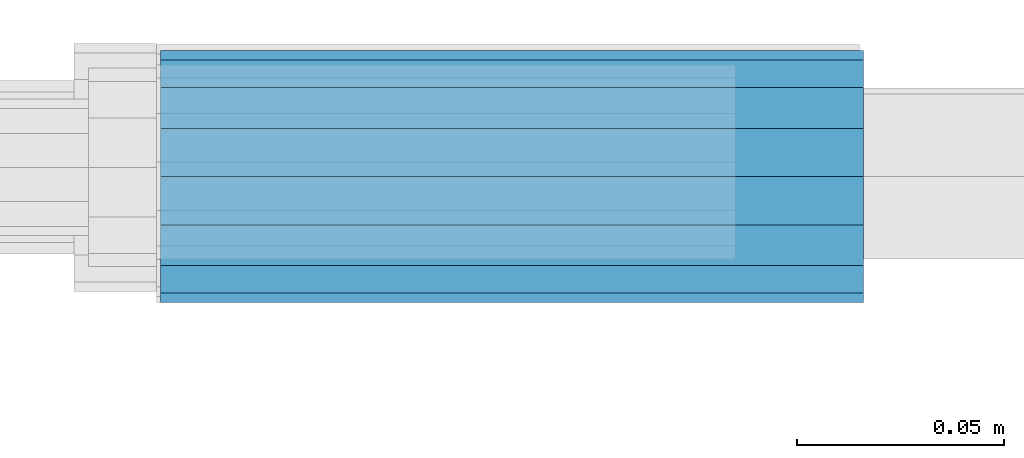
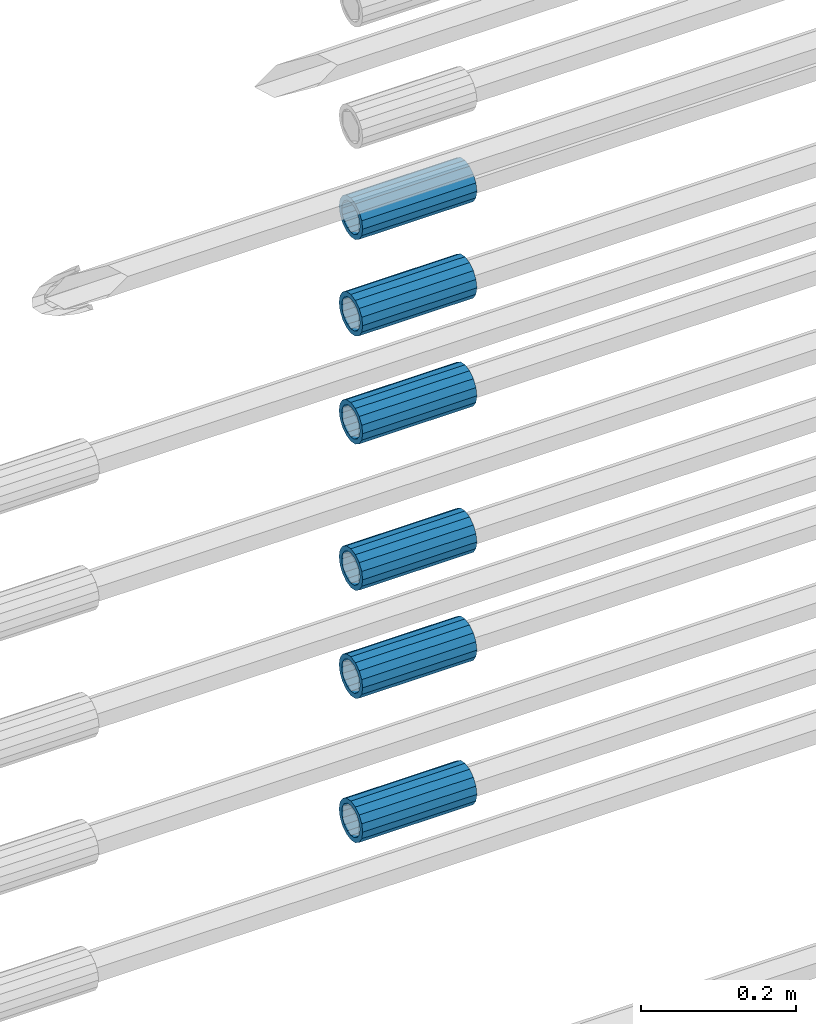
# One storey, part 12 of 119: 6 beams.
"""IFC2X3 building model written with IfcOpenShell, lengths in millimetres."""

from ifc_helpers import new_model, si_unit, frame, origin_with_axes, place, context, subcontext, project, spatial, faceted_brep, material, type_object, element, save


model = new_model("IFC2X3")

# Units and contexts
model_context = context("Model", 3, precision=1e-05, world=origin_with_axes())
body_context = subcontext(model_context, "Body", "Model", "MODEL_VIEW")
ifc_project = project(units=[si_unit("LENGTHUNIT", "METRE", prefix="MILLI"), si_unit("AREAUNIT", "SQUARE_METRE"), si_unit("VOLUMEUNIT", "CUBIC_METRE"), si_unit("MASSUNIT", "GRAM", prefix="KILO"), si_unit("TIMEUNIT", "SECOND"), si_unit("PLANEANGLEUNIT", "RADIAN"), si_unit("SOLIDANGLEUNIT", "STERADIAN"), si_unit("THERMODYNAMICTEMPERATUREUNIT", "DEGREE_CELSIUS"), si_unit("LUMINOUSINTENSITYUNIT", "LUMEN")], contexts=[model_context])

# Site, building, storey
site_placement = place(None, origin_with_axes())
site = spatial("IfcSite", under=ifc_project, at=site_placement, CompositionType="ELEMENT")
building_placement = place(site_placement, origin_with_axes())
building = spatial("IfcBuilding", under=site, at=building_placement, Name="Undefined", CompositionType="ELEMENT")
storey_placement = place(building_placement, origin_with_axes())
storey = spatial("IfcBuildingStorey", under=building, at=storey_placement, Name="Undefined", CompositionType="ELEMENT", Elevation=0.0)

# Beams
ifc_material = material(Name="STEEL/S275")
beam_type = type_object("IfcBeamType", PredefinedType="NOTDEFINED")
beam_1_placement = place(storey_placement, frame((2032020.00007889, 6206399.98994599, 19957.6893084732), z_axis=(0.0, 0.0, 1.0), x_axis=(-0.99999999999998, 1.98000110685822e-07, 0.0)))
element("IfcBeam", 1, at=beam_1_placement, inside=storey, type_object=beam_type, material=ifc_material, Name="AG40N", context=body_context, shape_type="Brep", body=[
    faceted_brep([(1.62981450557709e-09, -23.4999999990687, 0.0), (7.45058059692383e-09, -21.7111690142192, 8.99306066057534), (170.000002125278, -21.711168999318, 8.99306066022245), (170.000002127141, -23.4999999844003, -3.66071617463604e-10), (4.65661287307739e-09, -16.6170093587134, 16.6170093578889), (170.000002122484, -16.6170093440451, 16.6170093575288), (1.86264514923096e-09, -8.99306066217832, 21.7111690140277), (170.000002118759, -8.99306064750999, 21.7111690136603), (2.3283064365387e-10, 9.31322574615479e-10, 23.5), (170.000002114102, 1.28056854009628e-08, 23.4999999996485), (-6.51925802230835e-09, 8.99306065868586, 21.7111690140241), (170.00000211224, 8.99306067335419, 21.7111690136639), (-7.45058059692383e-09, 16.6170093561523, 16.6170093578853), (170.000002109446, 16.6170093708206, 16.6170093575324), (-9.31322574615479e-09, 21.711169013055, 8.99306066057534), (170.000002108514, 21.7111690277234, 8.99306066022245), (-1.16415321826935e-09, 23.5000000009313, 0.0), (170.000002108514, 23.5000000144355, -3.66071617463604e-10), (-8.38190317153931e-09, 21.7111690151505, -8.99306066059444), (170.000002110377, 21.7111690300517, -8.9930606609546), (-5.58793544769287e-09, 16.6170093598776, -16.6170093579008), (170.000002113171, 16.6170093745459, -16.6170093582609), (-9.31322574615479e-10, 8.99306066334248, -21.7111690140396), (170.000002115965, 8.99306067801081, -21.7111690143961), (2.3283064365387e-10, 9.31322574615479e-10, -23.5), (170.00000211969, 1.7927959561348e-08, -23.5000000003843), (5.58793544769287e-09, -8.99306065752171, -21.7111690140396), (170.000002123415, -8.99306064285338, -21.7111690143961), (8.38190317153931e-09, -16.6170093549881, -16.6170093579008), (170.000002125278, -16.6170093403198, -16.6170093582646), (9.31322574615479e-09, -21.7111690121237, -8.99306066059444), (170.000002127141, -21.7111689972226, -8.9930606609546), (1.11758708953857e-08, -30.4999999990687, -9.54969436861575e-12), (1.30385160446167e-08, -28.1783257392235, -11.6718446871514), (170.000002129003, -28.1783257243223, -11.6718446875116), (170.000002129935, -30.4999999841675, -3.66071617463604e-10), (1.02445483207703e-08, -21.5667568228673, -21.5667568262129), (170.000002128072, -21.566756808199, -21.5667568265694), (7.45058059692383e-09, -11.6718446831219, -28.1783257416196), (170.000002125278, -11.6718446684536, -28.1783257419834), (3.72529029846191e-09, 3.95812094211578e-09, -30.5000000000277), (170.00000211969, 1.83936208486557e-08, -30.5000000003879), (-9.31322574615479e-10, 11.6718446905725, -28.1783257416232), (170.000002115965, 11.6718447052408, -28.1783257419797), (-6.51925802230835e-09, 21.5667568286881, -21.5667568262093), (170.000002110377, 21.5667568433564, -21.5667568265694), (-9.31322574615479e-09, 28.178325742716, -11.6718446871478), (170.000002108514, 28.1783257573843, -11.6718446875079), (-1.21071934700012e-08, 30.5, -5.91171556152403e-12), (170.000002106652, 30.5000000144355, -3.62433638656512e-10), (-1.21071934700012e-08, 28.1783257401548, 11.6718446871359), (170.00000210572, 28.1783257548232, 11.6718446867794), (-1.02445483207703e-08, 21.5667568240315, 21.5667568261974), (170.000002107583, 21.566756838467, 21.5667568258409), (-7.45058059692383e-09, 11.671844684286, 28.1783257416041), (170.000002110377, 11.6718446989544, 28.178325741244), (-2.79396772384644e-09, -2.56113708019257e-09, 30.5000000000159), (170.000002114102, 1.18743628263474e-08, 30.4999999996558), (1.86264514923096e-09, -11.6718446896411, 28.1783257416114), (170.000002118759, -11.67184467474, 28.178325741244), (7.45058059692383e-09, -21.5667568275239, 21.5667568261974), (170.000002123415, -21.5667568126228, 21.5667568258373), (1.02445483207703e-08, -28.1783257415518, 11.6718446871359), (170.000002127141, -28.1783257271163, 11.6718446867794)], [[[0, 1, 2, 3]], [[1, 4, 5, 2]], [[4, 6, 7, 5]], [[6, 8, 9, 7]], [[8, 10, 11, 9]], [[10, 12, 13, 11]], [[12, 14, 15, 13]], [[14, 16, 17, 15]], [[16, 18, 19, 17]], [[18, 20, 21, 19]], [[20, 22, 23, 21]], [[22, 24, 25, 23]], [[24, 26, 27, 25]], [[26, 28, 29, 27]], [[28, 30, 31, 29]], [[30, 0, 3, 31]], [[32, 33, 34, 35]], [[33, 36, 37, 34]], [[36, 38, 39, 37]], [[38, 40, 41, 39]], [[40, 42, 43, 41]], [[42, 44, 45, 43]], [[44, 46, 47, 45]], [[46, 48, 49, 47]], [[48, 50, 51, 49]], [[50, 52, 53, 51]], [[52, 54, 55, 53]], [[54, 56, 57, 55]], [[56, 58, 59, 57]], [[58, 60, 61, 59]], [[60, 62, 63, 61]], [[62, 32, 35, 63]], [[37, 39, 41, 43, 45, 47, 49, 51, 53, 55, 57, 59, 61, 63, 35, 34], [5, 7, 9, 11, 13, 15, 17, 19, 21, 23, 25, 27, 29, 31, 3, 2]], [[62, 60, 58, 56, 54, 52, 50, 48, 46, 44, 42, 40, 38, 36, 33, 32], [30, 28, 26, 24, 22, 20, 18, 16, 14, 12, 10, 8, 6, 4, 1, 0]]]),
])
beam_2_placement = place(storey_placement, frame((2032020.00007889, 6206399.98994599, 20184.6893084732), z_axis=(0.0, 0.0, 1.0), x_axis=(-0.99999999999998, 1.98000110685822e-07, 0.0)))
element("IfcBeam", 2, at=beam_2_placement, inside=storey, type_object=beam_type, material=ifc_material, Name="AG40N", context=body_context, shape_type="Brep", body=[
    faceted_brep([(1.62981450557709e-09, -23.4999999990687, 0.0), (7.45058059692383e-09, -21.7111690142192, 8.99306066057534), (170.000002125278, -21.711168999318, 8.99306066022245), (170.000002127141, -23.4999999844003, -3.66071617463604e-10), (4.65661287307739e-09, -16.6170093587134, 16.6170093578889), (170.000002122484, -16.6170093440451, 16.6170093575288), (1.86264514923096e-09, -8.99306066217832, 21.7111690140277), (170.000002118759, -8.99306064750999, 21.7111690136603), (2.3283064365387e-10, 9.31322574615479e-10, 23.5), (170.000002114102, 1.28056854009628e-08, 23.4999999996485), (-6.51925802230835e-09, 8.99306065868586, 21.7111690140241), (170.00000211224, 8.99306067335419, 21.7111690136639), (-7.45058059692383e-09, 16.6170093561523, 16.6170093578853), (170.000002109446, 16.6170093708206, 16.6170093575324), (-9.31322574615479e-09, 21.711169013055, 8.99306066057534), (170.000002108514, 21.7111690277234, 8.99306066022245), (-1.16415321826935e-09, 23.5000000009313, 0.0), (170.000002108514, 23.5000000144355, -3.66071617463604e-10), (-8.38190317153931e-09, 21.7111690151505, -8.99306066059444), (170.000002110377, 21.7111690300517, -8.9930606609546), (-5.58793544769287e-09, 16.6170093598776, -16.6170093579008), (170.000002113171, 16.6170093745459, -16.6170093582609), (-9.31322574615479e-10, 8.99306066334248, -21.7111690140396), (170.000002115965, 8.99306067801081, -21.7111690143961), (2.3283064365387e-10, 9.31322574615479e-10, -23.5), (170.00000211969, 1.7927959561348e-08, -23.5000000003843), (5.58793544769287e-09, -8.99306065752171, -21.7111690140396), (170.000002123415, -8.99306064285338, -21.7111690143961), (8.38190317153931e-09, -16.6170093549881, -16.6170093579008), (170.000002125278, -16.6170093403198, -16.6170093582646), (9.31322574615479e-09, -21.7111690121237, -8.99306066059444), (170.000002127141, -21.7111689972226, -8.9930606609546), (1.11758708953857e-08, -30.4999999990687, -9.54969436861575e-12), (1.30385160446167e-08, -28.1783257392235, -11.6718446871514), (170.000002129003, -28.1783257243223, -11.6718446875116), (170.000002129935, -30.4999999841675, -3.66071617463604e-10), (1.02445483207703e-08, -21.5667568228673, -21.5667568262129), (170.000002128072, -21.566756808199, -21.5667568265694), (7.45058059692383e-09, -11.6718446831219, -28.1783257416196), (170.000002125278, -11.6718446684536, -28.1783257419834), (3.72529029846191e-09, 3.95812094211578e-09, -30.5000000000277), (170.00000211969, 1.83936208486557e-08, -30.5000000003879), (-9.31322574615479e-10, 11.6718446905725, -28.1783257416232), (170.000002115965, 11.6718447052408, -28.1783257419797), (-6.51925802230835e-09, 21.5667568286881, -21.5667568262093), (170.000002110377, 21.5667568433564, -21.5667568265694), (-9.31322574615479e-09, 28.178325742716, -11.6718446871478), (170.000002108514, 28.1783257573843, -11.6718446875079), (-1.21071934700012e-08, 30.5, -5.91171556152403e-12), (170.000002106652, 30.5000000144355, -3.62433638656512e-10), (-1.21071934700012e-08, 28.1783257401548, 11.6718446871359), (170.00000210572, 28.1783257548232, 11.6718446867794), (-1.02445483207703e-08, 21.5667568240315, 21.5667568261974), (170.000002107583, 21.566756838467, 21.5667568258409), (-7.45058059692383e-09, 11.671844684286, 28.1783257416041), (170.000002110377, 11.6718446989544, 28.178325741244), (-2.79396772384644e-09, -2.56113708019257e-09, 30.5000000000159), (170.000002114102, 1.18743628263474e-08, 30.4999999996558), (1.86264514923096e-09, -11.6718446896411, 28.1783257416114), (170.000002118759, -11.67184467474, 28.178325741244), (7.45058059692383e-09, -21.5667568275239, 21.5667568261974), (170.000002123415, -21.5667568126228, 21.5667568258373), (1.02445483207703e-08, -28.1783257415518, 11.6718446871359), (170.000002127141, -28.1783257271163, 11.6718446867794)], [[[0, 1, 2, 3]], [[1, 4, 5, 2]], [[4, 6, 7, 5]], [[6, 8, 9, 7]], [[8, 10, 11, 9]], [[10, 12, 13, 11]], [[12, 14, 15, 13]], [[14, 16, 17, 15]], [[16, 18, 19, 17]], [[18, 20, 21, 19]], [[20, 22, 23, 21]], [[22, 24, 25, 23]], [[24, 26, 27, 25]], [[26, 28, 29, 27]], [[28, 30, 31, 29]], [[30, 0, 3, 31]], [[32, 33, 34, 35]], [[33, 36, 37, 34]], [[36, 38, 39, 37]], [[38, 40, 41, 39]], [[40, 42, 43, 41]], [[42, 44, 45, 43]], [[44, 46, 47, 45]], [[46, 48, 49, 47]], [[48, 50, 51, 49]], [[50, 52, 53, 51]], [[52, 54, 55, 53]], [[54, 56, 57, 55]], [[56, 58, 59, 57]], [[58, 60, 61, 59]], [[60, 62, 63, 61]], [[62, 32, 35, 63]], [[37, 39, 41, 43, 45, 47, 49, 51, 53, 55, 57, 59, 61, 63, 35, 34], [5, 7, 9, 11, 13, 15, 17, 19, 21, 23, 25, 27, 29, 31, 3, 2]], [[62, 60, 58, 56, 54, 52, 50, 48, 46, 44, 42, 40, 38, 36, 33, 32], [30, 28, 26, 24, 22, 20, 18, 16, 14, 12, 10, 8, 6, 4, 1, 0]]]),
])
beam_3_placement = place(storey_placement, frame((2032020.00007889, 6206399.98994599, 20354.6893084732), z_axis=(0.0, 0.0, 1.0), x_axis=(-0.99999999999998, 1.98000110685822e-07, 0.0)))
element("IfcBeam", 3, at=beam_3_placement, inside=storey, type_object=beam_type, material=ifc_material, Name="AG40N", context=body_context, shape_type="Brep", body=[
    faceted_brep([(1.62981450557709e-09, -23.4999999990687, 0.0), (7.45058059692383e-09, -21.7111690142192, 8.99306066057534), (170.000002125278, -21.711168999318, 8.99306066022245), (170.000002127141, -23.4999999844003, -3.66071617463604e-10), (4.65661287307739e-09, -16.6170093587134, 16.6170093578889), (170.000002122484, -16.6170093440451, 16.6170093575288), (1.86264514923096e-09, -8.99306066217832, 21.7111690140277), (170.000002118759, -8.99306064750999, 21.7111690136603), (2.3283064365387e-10, 9.31322574615479e-10, 23.5), (170.000002114102, 1.28056854009628e-08, 23.4999999996485), (-6.51925802230835e-09, 8.99306065868586, 21.7111690140241), (170.00000211224, 8.99306067335419, 21.7111690136639), (-7.45058059692383e-09, 16.6170093561523, 16.6170093578853), (170.000002109446, 16.6170093708206, 16.6170093575324), (-9.31322574615479e-09, 21.711169013055, 8.99306066057534), (170.000002108514, 21.7111690277234, 8.99306066022245), (-1.16415321826935e-09, 23.5000000009313, 0.0), (170.000002108514, 23.5000000144355, -3.66071617463604e-10), (-8.38190317153931e-09, 21.7111690151505, -8.99306066059444), (170.000002110377, 21.7111690300517, -8.9930606609546), (-5.58793544769287e-09, 16.6170093598776, -16.6170093579008), (170.000002113171, 16.6170093745459, -16.6170093582609), (-9.31322574615479e-10, 8.99306066334248, -21.7111690140396), (170.000002115965, 8.99306067801081, -21.7111690143961), (2.3283064365387e-10, 9.31322574615479e-10, -23.5), (170.00000211969, 1.7927959561348e-08, -23.5000000003843), (5.58793544769287e-09, -8.99306065752171, -21.7111690140396), (170.000002123415, -8.99306064285338, -21.7111690143961), (8.38190317153931e-09, -16.6170093549881, -16.6170093579008), (170.000002125278, -16.6170093403198, -16.6170093582646), (9.31322574615479e-09, -21.7111690121237, -8.99306066059444), (170.000002127141, -21.7111689972226, -8.9930606609546), (1.11758708953857e-08, -30.4999999990687, -9.54969436861575e-12), (1.30385160446167e-08, -28.1783257392235, -11.6718446871514), (170.000002129003, -28.1783257243223, -11.6718446875116), (170.000002129935, -30.4999999841675, -3.66071617463604e-10), (1.02445483207703e-08, -21.5667568228673, -21.5667568262129), (170.000002128072, -21.566756808199, -21.5667568265694), (7.45058059692383e-09, -11.6718446831219, -28.1783257416196), (170.000002125278, -11.6718446684536, -28.1783257419834), (3.72529029846191e-09, 3.95812094211578e-09, -30.5000000000277), (170.00000211969, 1.83936208486557e-08, -30.5000000003879), (-9.31322574615479e-10, 11.6718446905725, -28.1783257416232), (170.000002115965, 11.6718447052408, -28.1783257419797), (-6.51925802230835e-09, 21.5667568286881, -21.5667568262093), (170.000002110377, 21.5667568433564, -21.5667568265694), (-9.31322574615479e-09, 28.178325742716, -11.6718446871478), (170.000002108514, 28.1783257573843, -11.6718446875079), (-1.21071934700012e-08, 30.5, -5.91171556152403e-12), (170.000002106652, 30.5000000144355, -3.62433638656512e-10), (-1.21071934700012e-08, 28.1783257401548, 11.6718446871359), (170.00000210572, 28.1783257548232, 11.6718446867794), (-1.02445483207703e-08, 21.5667568240315, 21.5667568261974), (170.000002107583, 21.566756838467, 21.5667568258409), (-7.45058059692383e-09, 11.671844684286, 28.1783257416041), (170.000002110377, 11.6718446989544, 28.178325741244), (-2.79396772384644e-09, -2.56113708019257e-09, 30.5000000000159), (170.000002114102, 1.18743628263474e-08, 30.4999999996558), (1.86264514923096e-09, -11.6718446896411, 28.1783257416114), (170.000002118759, -11.67184467474, 28.178325741244), (7.45058059692383e-09, -21.5667568275239, 21.5667568261974), (170.000002123415, -21.5667568126228, 21.5667568258373), (1.02445483207703e-08, -28.1783257415518, 11.6718446871359), (170.000002127141, -28.1783257271163, 11.6718446867794)], [[[0, 1, 2, 3]], [[1, 4, 5, 2]], [[4, 6, 7, 5]], [[6, 8, 9, 7]], [[8, 10, 11, 9]], [[10, 12, 13, 11]], [[12, 14, 15, 13]], [[14, 16, 17, 15]], [[16, 18, 19, 17]], [[18, 20, 21, 19]], [[20, 22, 23, 21]], [[22, 24, 25, 23]], [[24, 26, 27, 25]], [[26, 28, 29, 27]], [[28, 30, 31, 29]], [[30, 0, 3, 31]], [[32, 33, 34, 35]], [[33, 36, 37, 34]], [[36, 38, 39, 37]], [[38, 40, 41, 39]], [[40, 42, 43, 41]], [[42, 44, 45, 43]], [[44, 46, 47, 45]], [[46, 48, 49, 47]], [[48, 50, 51, 49]], [[50, 52, 53, 51]], [[52, 54, 55, 53]], [[54, 56, 57, 55]], [[56, 58, 59, 57]], [[58, 60, 61, 59]], [[60, 62, 63, 61]], [[62, 32, 35, 63]], [[37, 39, 41, 43, 45, 47, 49, 51, 53, 55, 57, 59, 61, 63, 35, 34], [5, 7, 9, 11, 13, 15, 17, 19, 21, 23, 25, 27, 29, 31, 3, 2]], [[62, 60, 58, 56, 54, 52, 50, 48, 46, 44, 42, 40, 38, 36, 33, 32], [30, 28, 26, 24, 22, 20, 18, 16, 14, 12, 10, 8, 6, 4, 1, 0]]]),
])
beam_4_placement = place(storey_placement, frame((2032020.00007889, 6206399.98994599, 20584.6893084732), z_axis=(0.0, 0.0, 1.0), x_axis=(-0.99999999999998, 1.98000110685822e-07, 0.0)))
element("IfcBeam", 4, at=beam_4_placement, inside=storey, type_object=beam_type, material=ifc_material, Name="AG40N", context=body_context, shape_type="Brep", body=[
    faceted_brep([(1.62981450557709e-09, -23.4999999990687, 0.0), (7.45058059692383e-09, -21.7111690142192, 8.99306066057534), (170.000002125278, -21.711168999318, 8.99306066022245), (170.000002127141, -23.4999999844003, -3.66071617463604e-10), (4.65661287307739e-09, -16.6170093587134, 16.6170093578889), (170.000002122484, -16.6170093440451, 16.6170093575288), (1.86264514923096e-09, -8.99306066217832, 21.7111690140277), (170.000002118759, -8.99306064750999, 21.7111690136603), (2.3283064365387e-10, 9.31322574615479e-10, 23.5), (170.000002114102, 1.28056854009628e-08, 23.4999999996485), (-6.51925802230835e-09, 8.99306065868586, 21.7111690140241), (170.00000211224, 8.99306067335419, 21.7111690136639), (-7.45058059692383e-09, 16.6170093561523, 16.6170093578853), (170.000002109446, 16.6170093708206, 16.6170093575324), (-9.31322574615479e-09, 21.711169013055, 8.99306066057534), (170.000002108514, 21.7111690277234, 8.99306066022245), (-1.16415321826935e-09, 23.5000000009313, 0.0), (170.000002108514, 23.5000000144355, -3.66071617463604e-10), (-8.38190317153931e-09, 21.7111690151505, -8.99306066059444), (170.000002110377, 21.7111690300517, -8.9930606609546), (-5.58793544769287e-09, 16.6170093598776, -16.6170093579008), (170.000002113171, 16.6170093745459, -16.6170093582609), (-9.31322574615479e-10, 8.99306066334248, -21.7111690140396), (170.000002115965, 8.99306067801081, -21.7111690143961), (2.3283064365387e-10, 9.31322574615479e-10, -23.5), (170.00000211969, 1.7927959561348e-08, -23.5000000003843), (5.58793544769287e-09, -8.99306065752171, -21.7111690140396), (170.000002123415, -8.99306064285338, -21.7111690143961), (8.38190317153931e-09, -16.6170093549881, -16.6170093579008), (170.000002125278, -16.6170093403198, -16.6170093582646), (9.31322574615479e-09, -21.7111690121237, -8.99306066059444), (170.000002127141, -21.7111689972226, -8.9930606609546), (1.11758708953857e-08, -30.4999999990687, -9.54969436861575e-12), (1.30385160446167e-08, -28.1783257392235, -11.6718446871514), (170.000002129003, -28.1783257243223, -11.6718446875116), (170.000002129935, -30.4999999841675, -3.66071617463604e-10), (1.02445483207703e-08, -21.5667568228673, -21.5667568262129), (170.000002128072, -21.566756808199, -21.5667568265694), (7.45058059692383e-09, -11.6718446831219, -28.1783257416196), (170.000002125278, -11.6718446684536, -28.1783257419834), (3.72529029846191e-09, 3.95812094211578e-09, -30.5000000000277), (170.00000211969, 1.83936208486557e-08, -30.5000000003879), (-9.31322574615479e-10, 11.6718446905725, -28.1783257416232), (170.000002115965, 11.6718447052408, -28.1783257419797), (-6.51925802230835e-09, 21.5667568286881, -21.5667568262093), (170.000002110377, 21.5667568433564, -21.5667568265694), (-9.31322574615479e-09, 28.178325742716, -11.6718446871478), (170.000002108514, 28.1783257573843, -11.6718446875079), (-1.21071934700012e-08, 30.5, -5.91171556152403e-12), (170.000002106652, 30.5000000144355, -3.62433638656512e-10), (-1.21071934700012e-08, 28.1783257401548, 11.6718446871359), (170.00000210572, 28.1783257548232, 11.6718446867794), (-1.02445483207703e-08, 21.5667568240315, 21.5667568261974), (170.000002107583, 21.566756838467, 21.5667568258409), (-7.45058059692383e-09, 11.671844684286, 28.1783257416041), (170.000002110377, 11.6718446989544, 28.178325741244), (-2.79396772384644e-09, -2.56113708019257e-09, 30.5000000000159), (170.000002114102, 1.18743628263474e-08, 30.4999999996558), (1.86264514923096e-09, -11.6718446896411, 28.1783257416114), (170.000002118759, -11.67184467474, 28.178325741244), (7.45058059692383e-09, -21.5667568275239, 21.5667568261974), (170.000002123415, -21.5667568126228, 21.5667568258373), (1.02445483207703e-08, -28.1783257415518, 11.6718446871359), (170.000002127141, -28.1783257271163, 11.6718446867794)], [[[0, 1, 2, 3]], [[1, 4, 5, 2]], [[4, 6, 7, 5]], [[6, 8, 9, 7]], [[8, 10, 11, 9]], [[10, 12, 13, 11]], [[12, 14, 15, 13]], [[14, 16, 17, 15]], [[16, 18, 19, 17]], [[18, 20, 21, 19]], [[20, 22, 23, 21]], [[22, 24, 25, 23]], [[24, 26, 27, 25]], [[26, 28, 29, 27]], [[28, 30, 31, 29]], [[30, 0, 3, 31]], [[32, 33, 34, 35]], [[33, 36, 37, 34]], [[36, 38, 39, 37]], [[38, 40, 41, 39]], [[40, 42, 43, 41]], [[42, 44, 45, 43]], [[44, 46, 47, 45]], [[46, 48, 49, 47]], [[48, 50, 51, 49]], [[50, 52, 53, 51]], [[52, 54, 55, 53]], [[54, 56, 57, 55]], [[56, 58, 59, 57]], [[58, 60, 61, 59]], [[60, 62, 63, 61]], [[62, 32, 35, 63]], [[37, 39, 41, 43, 45, 47, 49, 51, 53, 55, 57, 59, 61, 63, 35, 34], [5, 7, 9, 11, 13, 15, 17, 19, 21, 23, 25, 27, 29, 31, 3, 2]], [[62, 60, 58, 56, 54, 52, 50, 48, 46, 44, 42, 40, 38, 36, 33, 32], [30, 28, 26, 24, 22, 20, 18, 16, 14, 12, 10, 8, 6, 4, 1, 0]]]),
])
beam_5_placement = place(storey_placement, frame((2032020.00007889, 6206399.98994599, 20754.6893084732), z_axis=(0.0, 0.0, 1.0), x_axis=(-0.99999999999998, 1.98000110685822e-07, 0.0)))
element("IfcBeam", 5, at=beam_5_placement, inside=storey, type_object=beam_type, material=ifc_material, Name="AG40N", context=body_context, shape_type="Brep", body=[
    faceted_brep([(1.62981450557709e-09, -23.4999999990687, 0.0), (7.45058059692383e-09, -21.7111690142192, 8.99306066057534), (170.000002125278, -21.711168999318, 8.99306066022245), (170.000002127141, -23.4999999844003, -3.66071617463604e-10), (4.65661287307739e-09, -16.6170093587134, 16.6170093578889), (170.000002122484, -16.6170093440451, 16.6170093575288), (1.86264514923096e-09, -8.99306066217832, 21.7111690140277), (170.000002118759, -8.99306064750999, 21.7111690136603), (2.3283064365387e-10, 9.31322574615479e-10, 23.5), (170.000002114102, 1.28056854009628e-08, 23.4999999996485), (-6.51925802230835e-09, 8.99306065868586, 21.7111690140241), (170.00000211224, 8.99306067335419, 21.7111690136639), (-7.45058059692383e-09, 16.6170093561523, 16.6170093578853), (170.000002109446, 16.6170093708206, 16.6170093575324), (-9.31322574615479e-09, 21.711169013055, 8.99306066057534), (170.000002108514, 21.7111690277234, 8.99306066022245), (-1.16415321826935e-09, 23.5000000009313, 0.0), (170.000002108514, 23.5000000144355, -3.66071617463604e-10), (-8.38190317153931e-09, 21.7111690151505, -8.99306066059444), (170.000002110377, 21.7111690300517, -8.9930606609546), (-5.58793544769287e-09, 16.6170093598776, -16.6170093579008), (170.000002113171, 16.6170093745459, -16.6170093582609), (-9.31322574615479e-10, 8.99306066334248, -21.7111690140396), (170.000002115965, 8.99306067801081, -21.7111690143961), (2.3283064365387e-10, 9.31322574615479e-10, -23.5), (170.00000211969, 1.7927959561348e-08, -23.5000000003843), (5.58793544769287e-09, -8.99306065752171, -21.7111690140396), (170.000002123415, -8.99306064285338, -21.7111690143961), (8.38190317153931e-09, -16.6170093549881, -16.6170093579008), (170.000002125278, -16.6170093403198, -16.6170093582646), (9.31322574615479e-09, -21.7111690121237, -8.99306066059444), (170.000002127141, -21.7111689972226, -8.9930606609546), (1.11758708953857e-08, -30.4999999990687, -9.54969436861575e-12), (1.30385160446167e-08, -28.1783257392235, -11.6718446871514), (170.000002129003, -28.1783257243223, -11.6718446875116), (170.000002129935, -30.4999999841675, -3.66071617463604e-10), (1.02445483207703e-08, -21.5667568228673, -21.5667568262129), (170.000002128072, -21.566756808199, -21.5667568265694), (7.45058059692383e-09, -11.6718446831219, -28.1783257416196), (170.000002125278, -11.6718446684536, -28.1783257419834), (3.72529029846191e-09, 3.95812094211578e-09, -30.5000000000277), (170.00000211969, 1.83936208486557e-08, -30.5000000003879), (-9.31322574615479e-10, 11.6718446905725, -28.1783257416232), (170.000002115965, 11.6718447052408, -28.1783257419797), (-6.51925802230835e-09, 21.5667568286881, -21.5667568262093), (170.000002110377, 21.5667568433564, -21.5667568265694), (-9.31322574615479e-09, 28.178325742716, -11.6718446871478), (170.000002108514, 28.1783257573843, -11.6718446875079), (-1.21071934700012e-08, 30.5, -5.91171556152403e-12), (170.000002106652, 30.5000000144355, -3.62433638656512e-10), (-1.21071934700012e-08, 28.1783257401548, 11.6718446871359), (170.00000210572, 28.1783257548232, 11.6718446867794), (-1.02445483207703e-08, 21.5667568240315, 21.5667568261974), (170.000002107583, 21.566756838467, 21.5667568258409), (-7.45058059692383e-09, 11.671844684286, 28.1783257416041), (170.000002110377, 11.6718446989544, 28.178325741244), (-2.79396772384644e-09, -2.56113708019257e-09, 30.5000000000159), (170.000002114102, 1.18743628263474e-08, 30.4999999996558), (1.86264514923096e-09, -11.6718446896411, 28.1783257416114), (170.000002118759, -11.67184467474, 28.178325741244), (7.45058059692383e-09, -21.5667568275239, 21.5667568261974), (170.000002123415, -21.5667568126228, 21.5667568258373), (1.02445483207703e-08, -28.1783257415518, 11.6718446871359), (170.000002127141, -28.1783257271163, 11.6718446867794)], [[[0, 1, 2, 3]], [[1, 4, 5, 2]], [[4, 6, 7, 5]], [[6, 8, 9, 7]], [[8, 10, 11, 9]], [[10, 12, 13, 11]], [[12, 14, 15, 13]], [[14, 16, 17, 15]], [[16, 18, 19, 17]], [[18, 20, 21, 19]], [[20, 22, 23, 21]], [[22, 24, 25, 23]], [[24, 26, 27, 25]], [[26, 28, 29, 27]], [[28, 30, 31, 29]], [[30, 0, 3, 31]], [[32, 33, 34, 35]], [[33, 36, 37, 34]], [[36, 38, 39, 37]], [[38, 40, 41, 39]], [[40, 42, 43, 41]], [[42, 44, 45, 43]], [[44, 46, 47, 45]], [[46, 48, 49, 47]], [[48, 50, 51, 49]], [[50, 52, 53, 51]], [[52, 54, 55, 53]], [[54, 56, 57, 55]], [[56, 58, 59, 57]], [[58, 60, 61, 59]], [[60, 62, 63, 61]], [[62, 32, 35, 63]], [[37, 39, 41, 43, 45, 47, 49, 51, 53, 55, 57, 59, 61, 63, 35, 34], [5, 7, 9, 11, 13, 15, 17, 19, 21, 23, 25, 27, 29, 31, 3, 2]], [[62, 60, 58, 56, 54, 52, 50, 48, 46, 44, 42, 40, 38, 36, 33, 32], [30, 28, 26, 24, 22, 20, 18, 16, 14, 12, 10, 8, 6, 4, 1, 0]]]),
])
beam_6_placement = place(storey_placement, frame((2032020.00007889, 6206399.98994599, 20906.4893084633), z_axis=(0.0, 0.0, 1.0), x_axis=(-0.99999999999998, 1.98000110685822e-07, 0.0)))
element("IfcBeam", 6, at=beam_6_placement, inside=storey, type_object=beam_type, material=ifc_material, Name="AG40N", context=body_context, shape_type="Brep", body=[
    faceted_brep([(1.62981450557709e-09, -23.4999999990687, 0.0), (7.45058059692383e-09, -21.7111690142192, 8.99306066057534), (170.000002125278, -21.711168999318, 8.99306066022245), (170.000002127141, -23.4999999844003, -3.66071617463604e-10), (4.65661287307739e-09, -16.6170093587134, 16.6170093578889), (170.000002122484, -16.6170093440451, 16.6170093575288), (1.86264514923096e-09, -8.99306066217832, 21.7111690140277), (170.000002118759, -8.99306064750999, 21.7111690136603), (2.3283064365387e-10, 9.31322574615479e-10, 23.5), (170.000002114102, 1.28056854009628e-08, 23.4999999996485), (-6.51925802230835e-09, 8.99306065868586, 21.7111690140241), (170.00000211224, 8.99306067335419, 21.7111690136639), (-7.45058059692383e-09, 16.6170093561523, 16.6170093578853), (170.000002109446, 16.6170093708206, 16.6170093575324), (-9.31322574615479e-09, 21.711169013055, 8.99306066057534), (170.000002108514, 21.7111690277234, 8.99306066022245), (-1.16415321826935e-09, 23.5000000009313, 0.0), (170.000002108514, 23.5000000144355, -3.66071617463604e-10), (-8.38190317153931e-09, 21.7111690151505, -8.99306066059444), (170.000002110377, 21.7111690300517, -8.9930606609546), (-5.58793544769287e-09, 16.6170093598776, -16.6170093579008), (170.000002113171, 16.6170093745459, -16.6170093582609), (-9.31322574615479e-10, 8.99306066334248, -21.7111690140396), (170.000002115965, 8.99306067801081, -21.7111690143961), (2.3283064365387e-10, 9.31322574615479e-10, -23.5), (170.00000211969, 1.7927959561348e-08, -23.5000000003843), (5.58793544769287e-09, -8.99306065752171, -21.7111690140396), (170.000002123415, -8.99306064285338, -21.7111690143961), (8.38190317153931e-09, -16.6170093549881, -16.6170093579008), (170.000002125278, -16.6170093403198, -16.6170093582646), (9.31322574615479e-09, -21.7111690121237, -8.99306066059444), (170.000002127141, -21.7111689972226, -8.9930606609546), (1.11758708953857e-08, -30.4999999990687, -9.54969436861575e-12), (1.30385160446167e-08, -28.1783257392235, -11.6718446871514), (170.000002129003, -28.1783257243223, -11.6718446875116), (170.000002129935, -30.4999999841675, -3.66071617463604e-10), (1.02445483207703e-08, -21.5667568228673, -21.5667568262129), (170.000002128072, -21.566756808199, -21.5667568265694), (7.45058059692383e-09, -11.6718446831219, -28.1783257416196), (170.000002125278, -11.6718446684536, -28.1783257419834), (3.72529029846191e-09, 3.95812094211578e-09, -30.5000000000277), (170.00000211969, 1.83936208486557e-08, -30.5000000003879), (-9.31322574615479e-10, 11.6718446905725, -28.1783257416232), (170.000002115965, 11.6718447052408, -28.1783257419797), (-6.51925802230835e-09, 21.5667568286881, -21.5667568262093), (170.000002110377, 21.5667568433564, -21.5667568265694), (-9.31322574615479e-09, 28.178325742716, -11.6718446871478), (170.000002108514, 28.1783257573843, -11.6718446875079), (-1.21071934700012e-08, 30.5, -5.91171556152403e-12), (170.000002106652, 30.5000000144355, -3.62433638656512e-10), (-1.21071934700012e-08, 28.1783257401548, 11.6718446871359), (170.00000210572, 28.1783257548232, 11.6718446867794), (-1.02445483207703e-08, 21.5667568240315, 21.5667568261974), (170.000002107583, 21.566756838467, 21.5667568258409), (-7.45058059692383e-09, 11.671844684286, 28.1783257416041), (170.000002110377, 11.6718446989544, 28.178325741244), (-2.79396772384644e-09, -2.56113708019257e-09, 30.5000000000159), (170.000002114102, 1.18743628263474e-08, 30.4999999996558), (1.86264514923096e-09, -11.6718446896411, 28.1783257416114), (170.000002118759, -11.67184467474, 28.178325741244), (7.45058059692383e-09, -21.5667568275239, 21.5667568261974), (170.000002123415, -21.5667568126228, 21.5667568258373), (1.02445483207703e-08, -28.1783257415518, 11.6718446871359), (170.000002127141, -28.1783257271163, 11.6718446867794)], [[[0, 1, 2, 3]], [[1, 4, 5, 2]], [[4, 6, 7, 5]], [[6, 8, 9, 7]], [[8, 10, 11, 9]], [[10, 12, 13, 11]], [[12, 14, 15, 13]], [[14, 16, 17, 15]], [[16, 18, 19, 17]], [[18, 20, 21, 19]], [[20, 22, 23, 21]], [[22, 24, 25, 23]], [[24, 26, 27, 25]], [[26, 28, 29, 27]], [[28, 30, 31, 29]], [[30, 0, 3, 31]], [[32, 33, 34, 35]], [[33, 36, 37, 34]], [[36, 38, 39, 37]], [[38, 40, 41, 39]], [[40, 42, 43, 41]], [[42, 44, 45, 43]], [[44, 46, 47, 45]], [[46, 48, 49, 47]], [[48, 50, 51, 49]], [[50, 52, 53, 51]], [[52, 54, 55, 53]], [[54, 56, 57, 55]], [[56, 58, 59, 57]], [[58, 60, 61, 59]], [[60, 62, 63, 61]], [[62, 32, 35, 63]], [[37, 39, 41, 43, 45, 47, 49, 51, 53, 55, 57, 59, 61, 63, 35, 34], [5, 7, 9, 11, 13, 15, 17, 19, 21, 23, 25, 27, 29, 31, 3, 2]], [[62, 60, 58, 56, 54, 52, 50, 48, 46, 44, 42, 40, 38, 36, 33, 32], [30, 28, 26, 24, 22, 20, 18, 16, 14, 12, 10, 8, 6, 4, 1, 0]]]),
])

save(model, "model.ifc")
